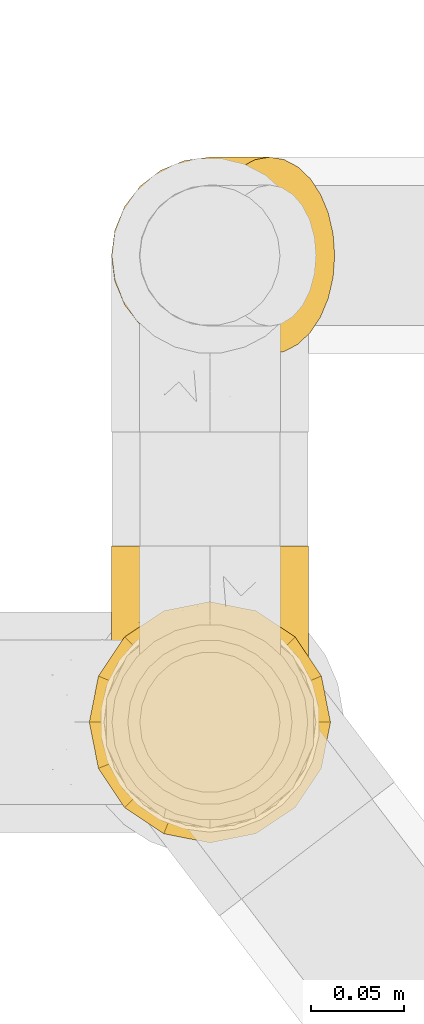
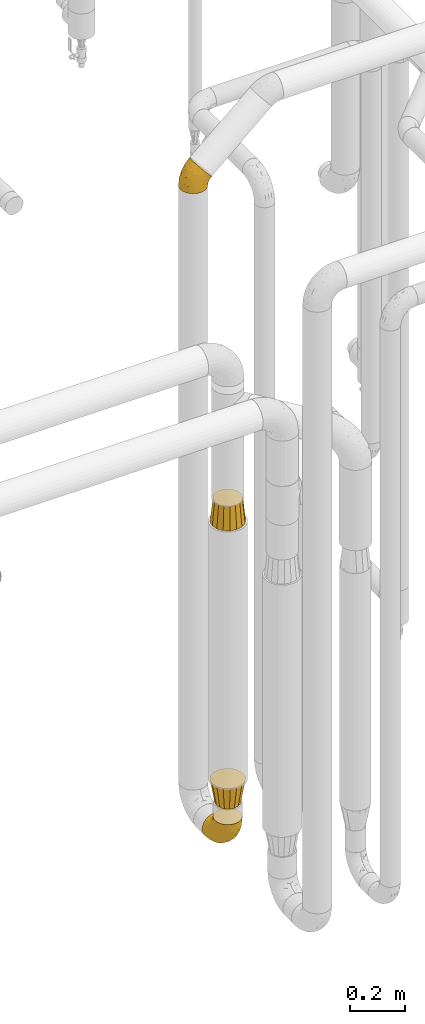
# One storey, part 393 of 827: 4 coverings.
"""IFC2X3 building model written with IfcOpenShell, lengths in millimetres."""

from ifc_helpers import new_model, entity, si_unit, converted_unit, derived_unit, direction, frame, origin, place, context, subcontext, project, spatial, faceted_brep, element, save


model = new_model("IFC2X3")

# Units and contexts
model_context = context("Model", 3, precision=0.01, world=origin(), true_north=direction((6.12303176911189e-17, 1.0)))
body_context = subcontext(model_context, "Body", "Model", "MODEL_VIEW")
ifc_project = project(units=[si_unit("LENGTHUNIT", "METRE", prefix="MILLI"), si_unit("AREAUNIT", "SQUARE_METRE"), si_unit("VOLUMEUNIT", "CUBIC_METRE"), converted_unit("PLANEANGLEUNIT", "DEGREE", entity("IfcRatioMeasure", 0.0174532925199433), si_unit("PLANEANGLEUNIT", "RADIAN"), dimensions=[0, 0, 0, 0, 0, 0, 0]), si_unit("MASSUNIT", "GRAM", prefix="KILO"), derived_unit("MASSDENSITYUNIT", [(si_unit("MASSUNIT", "GRAM", prefix="KILO"), 1), (si_unit("LENGTHUNIT", "METRE"), -3)]), derived_unit("MOMENTOFINERTIAUNIT", [(si_unit("LENGTHUNIT", "METRE"), 4)]), si_unit("TIMEUNIT", "SECOND"), si_unit("FREQUENCYUNIT", "HERTZ"), si_unit("THERMODYNAMICTEMPERATUREUNIT", "DEGREE_CELSIUS"), derived_unit("THERMALTRANSMITTANCEUNIT", [(si_unit("MASSUNIT", "GRAM", prefix="KILO"), 1), (si_unit("THERMODYNAMICTEMPERATUREUNIT", "KELVIN"), -1), (si_unit("TIMEUNIT", "SECOND"), -3)]), derived_unit("VOLUMETRICFLOWRATEUNIT", [(si_unit("LENGTHUNIT", "METRE"), 3), (si_unit("TIMEUNIT", "SECOND"), -1)]), derived_unit("MASSFLOWRATEUNIT", [(si_unit("MASSUNIT", "GRAM", prefix="KILO"), 1), (si_unit("TIMEUNIT", "SECOND"), -1)]), derived_unit("ROTATIONALFREQUENCYUNIT", [(si_unit("TIMEUNIT", "SECOND"), -1)]), si_unit("ELECTRICCURRENTUNIT", "AMPERE"), si_unit("ELECTRICVOLTAGEUNIT", "VOLT"), si_unit("POWERUNIT", "WATT"), si_unit("FORCEUNIT", "NEWTON", prefix="KILO"), si_unit("ILLUMINANCEUNIT", "LUX"), si_unit("LUMINOUSFLUXUNIT", "LUMEN"), si_unit("LUMINOUSINTENSITYUNIT", "CANDELA"), derived_unit("USERDEFINED", [(si_unit("MASSUNIT", "GRAM", prefix="KILO"), -1), (si_unit("LENGTHUNIT", "METRE"), -2), (si_unit("TIMEUNIT", "SECOND"), 3), (si_unit("LUMINOUSFLUXUNIT", "LUMEN"), 1)]), derived_unit("LINEARVELOCITYUNIT", [(si_unit("LENGTHUNIT", "METRE"), 1), (si_unit("TIMEUNIT", "SECOND"), -1)]), si_unit("PRESSUREUNIT", "PASCAL"), derived_unit("USERDEFINED", [(si_unit("LENGTHUNIT", "METRE"), -2), (si_unit("MASSUNIT", "GRAM", prefix="KILO"), 1), (si_unit("TIMEUNIT", "SECOND"), -2)]), derived_unit("LINEARFORCEUNIT", [(si_unit("MASSUNIT", "GRAM", prefix="KILO"), 1), (si_unit("LENGTHUNIT", "METRE"), 1), (si_unit("TIMEUNIT", "SECOND"), -2), (si_unit("LENGTHUNIT", "METRE"), -1)]), derived_unit("PLANARFORCEUNIT", [(si_unit("MASSUNIT", "GRAM", prefix="KILO"), 1), (si_unit("LENGTHUNIT", "METRE"), 1), (si_unit("TIMEUNIT", "SECOND"), -2), (si_unit("LENGTHUNIT", "METRE"), -2)])], contexts=[model_context])

# Site, building, storey
site_placement = place(None, origin())
site = spatial("IfcSite", under=ifc_project, at=site_placement, CompositionType="ELEMENT")
building_placement = place(site_placement, origin())
building = spatial("IfcBuilding", under=site, at=building_placement, CompositionType="ELEMENT")
storey_placement = place(building_placement, frame((0.0, 0.0, 28200.0)))
storey = spatial("IfcBuildingStorey", under=building, at=storey_placement, Name="08", CompositionType="ELEMENT", Elevation=28200.0)

# Coverings
covering_1_placement = place(storey_placement, frame((45439.58, 14231.97, 295.35)))
element("IfcCovering", 1, at=covering_1_placement, inside=storey, Name=":ADSK_", ObjectType=":ADSK_", PredefinedType="INSULATION", context=body_context, shape_type="Brep", body=[
    faceted_brep([(42.85, 2.92, 149.65), (54.65, 1.6, 149.65), (66.46, 2.93, 149.65), (77.67, 6.85, 149.65), (87.73, 13.18, 149.65), (96.13, 21.58, 149.65), (102.45, 31.64, 149.65), (106.37, 42.85, 149.65), (107.7, 54.65, 149.65), (106.36, 66.46, 149.65), (102.44, 77.67, 149.65), (96.11, 87.73, 149.65), (87.71, 96.13, 149.65), (77.65, 102.45, 149.65), (66.44, 106.37, 149.65), (54.65, 107.7, 149.65), (42.84, 106.36, 149.65), (31.62, 102.44, 149.65), (21.56, 96.11, 149.65), (13.16, 87.71, 149.65), (6.84, 77.65, 149.65), (2.92, 66.44, 149.65), (1.6, 54.65, 149.65), (2.93, 42.84, 149.65), (6.85, 31.62, 149.65), (13.18, 21.56, 149.65), (21.58, 13.16, 149.65), (31.64, 6.84, 149.65), (68.38, 149.65, 105.89), (81.17, 149.65, 100.59), (92.16, 149.65, 92.16), (100.59, 149.65, 81.17), (105.89, 149.65, 68.38), (107.7, 149.65, 54.65), (105.89, 149.65, 40.91), (100.59, 149.65, 28.12), (92.16, 149.65, 17.13), (81.17, 149.65, 8.7), (68.38, 149.65, 3.4), (54.65, 149.65, 1.6), (40.91, 149.65, 3.4), (28.12, 149.65, 8.7), (17.13, 149.65, 17.13), (8.7, 149.65, 28.12), (3.4, 149.65, 40.91), (1.6, 149.65, 54.65), (3.4, 149.65, 68.38), (8.7, 149.65, 81.17), (17.13, 149.65, 92.16), (28.12, 149.65, 100.59), (40.91, 149.65, 105.89), (54.65, 149.65, 107.7), (23.76, 123.27, 14.05), (35.87, 114.15, 9.45), (25.52, 92.97, 22.36), (45.07, 124.11, 4.7), (54.65, 111.33, 6.64), (12.57, 42.13, 81.47), (15.93, 56.83, 56.83), (24.82, 40.31, 64.02), (37.92, 61.55, 34.04), (54.65, 75.62, 21.43), (54.65, 44.96, 44.96), (5.82, 91.12, 49.8), (8.38, 109.83, 35.43), (10.19, 88.02, 42.1), (3.86, 119.19, 43.59), (2.5, 99.11, 57.88), (19.48, 27.97, 91.8), (29.7, 21.92, 88.01), (28.0, 12.94, 115.65), (35.28, 88.29, 18.94), (45.15, 95.35, 12.83), (14.54, 113.84, 24.96), (54.65, 6.64, 111.33), (38.55, 8.58, 113.8), (40.99, 33.39, 60.89), (43.24, 17.23, 86.24), (8.56, 61.99, 65.84), (2.51, 47.9, 124.58), (5.69, 37.72, 121.36), (1.6, 93.81, 72.79), (1.6, 107.05, 66.04), (1.6, 120.29, 59.29), (3.22, 73.26, 73.26), (18.7, 18.58, 121.69), (11.86, 29.72, 109.82), (24.78, 64.31, 40.11), (15.99, 82.84, 36.57), (1.6, 72.79, 93.81), (1.6, 83.3, 83.3), (1.6, 56.71, 136.6), (1.6, 59.29, 120.29), (2.5, 57.88, 99.11), (1.6, 66.04, 107.05), (5.82, 49.8, 91.12), (54.65, 21.43, 75.62), (1.6, 134.97, 56.97), (32.3, 108.79, 126.65), (25.01, 110.84, 116.55), (18.18, 101.53, 120.09), (3.03, 111.84, 76.06), (6.69, 119.98, 83.69), (3.21, 123.54, 71.88), (2.73, 134.54, 66.92), (3.93, 80.57, 110.43), (2.55, 69.55, 121.31), (7.7, 134.56, 81.0), (54.65, 128.67, 113.32), (54.65, 136.98, 111.09), (41.58, 133.56, 109.14), (17.93, 131.66, 95.86), (14.97, 117.75, 99.07), (22.2, 118.23, 106.92), (43.45, 110.55, 131.39), (54.65, 111.09, 136.98), (54.65, 113.32, 128.67), (40.37, 120.2, 117.07), (8.47, 105.95, 96.39), (29.46, 127.69, 106.61), (32.17, 139.88, 103.72), (3.39, 92.14, 92.14), (7.76, 93.82, 107.13), (2.57, 82.28, 98.03), (11.54, 130.86, 88.38), (6.21, 78.78, 130.66), (2.9, 67.58, 135.45), (11.19, 90.58, 123.57), (14.27, 90.23, 137.75), (22.4, 99.39, 133.2), (34.87, 105.17, 138.8), (54.65, 120.99, 120.99), (4.01, 104.59, 84.53), (16.42, 108.24, 108.72), (91.36, 131.66, 95.86), (103.07, 78.8, 130.67), (67.71, 133.57, 109.13), (107.7, 72.79, 93.81), (106.72, 82.27, 98.02), (105.35, 80.59, 110.43), (65.83, 110.55, 131.4), (76.97, 108.79, 126.66), (68.91, 120.2, 117.08), (92.85, 108.25, 108.74), (100.82, 106.06, 96.31), (94.28, 117.78, 99.11), (98.08, 90.6, 123.58), (101.51, 93.87, 107.12), (107.7, 93.81, 72.79), (107.7, 107.05, 66.04), (106.25, 111.89, 76.07), (107.7, 134.97, 56.97), (106.56, 134.54, 66.92), (107.7, 59.29, 120.29), (107.7, 66.04, 107.05), (106.74, 69.56, 121.26), (105.31, 104.56, 84.46), (102.6, 119.98, 83.69), (101.59, 134.56, 81.0), (106.08, 123.54, 71.88), (95.01, 90.25, 137.76), (86.87, 99.4, 133.21), (84.27, 110.83, 116.58), (91.11, 101.52, 120.1), (74.4, 105.18, 138.81), (107.7, 56.71, 136.6), (77.12, 139.89, 103.72), (87.06, 118.22, 106.96), (106.38, 67.6, 135.44), (97.75, 130.86, 88.38), (107.7, 83.3, 83.3), (79.83, 127.71, 106.6), (105.91, 92.12, 92.12), (107.7, 120.29, 59.29), (83.77, 92.97, 22.36), (85.53, 123.27, 14.05), (94.75, 113.84, 24.96), (100.91, 109.83, 35.43), (64.22, 124.03, 4.71), (73.42, 114.15, 9.45), (64.15, 98.04, 11.79), (106.79, 99.11, 57.88), (106.79, 47.9, 124.57), (103.61, 37.74, 121.37), (103.47, 49.8, 91.12), (93.36, 56.83, 56.83), (96.75, 42.16, 81.48), (84.48, 40.3, 64.05), (106.79, 57.88, 99.11), (106.07, 73.26, 73.26), (105.43, 119.19, 43.59), (73.44, 86.61, 19.5), (89.82, 27.99, 91.8), (90.61, 18.59, 121.7), (79.61, 21.92, 88.04), (81.34, 11.28, 123.34), (68.3, 33.39, 60.89), (71.37, 61.55, 34.04), (97.44, 29.73, 109.85), (99.1, 88.01, 42.1), (100.74, 62.08, 65.78), (70.76, 8.58, 113.81), (93.3, 82.84, 36.57), (84.5, 64.3, 40.12), (103.47, 91.12, 49.8), (68.73, 18.05, 86.08)], [[[0, 1, 2, 3, 4, 5, 6, 7, 8, 9, 10, 11, 12, 13, 14, 15, 16, 17, 18, 19, 20, 21, 22, 23, 24, 25, 26, 27]], [[28, 29, 30, 31, 32, 33, 34, 35, 36, 37, 38, 39, 40, 41, 42, 43, 44, 45, 46, 47, 48, 49, 50, 51]], [[52, 53, 54]], [[55, 39, 56]], [[57, 58, 59]], [[60, 61, 62]], [[63, 64, 65]], [[66, 63, 67]], [[68, 69, 70]], [[53, 71, 54]], [[41, 40, 53]], [[53, 72, 71]], [[73, 42, 52]], [[42, 41, 52]], [[74, 0, 75]], [[69, 76, 77]], [[43, 73, 64]], [[45, 44, 66]], [[57, 78, 58]], [[23, 79, 80]], [[67, 81, 82, 83]], [[67, 84, 81]], [[24, 23, 80]], [[25, 85, 26]], [[86, 85, 25]], [[42, 73, 43]], [[0, 27, 75]], [[25, 24, 86]], [[70, 26, 85]], [[0, 74, 1]], [[68, 85, 86]], [[66, 64, 63]], [[60, 59, 87]], [[54, 87, 88]], [[76, 60, 62]], [[84, 89, 90, 81]], [[79, 22, 91, 92]], [[77, 74, 75]], [[93, 92, 94, 89]], [[80, 86, 24]], [[40, 55, 53]], [[76, 59, 60]], [[93, 84, 95]], [[76, 62, 96]], [[55, 72, 53]], [[70, 27, 26]], [[75, 70, 69]], [[78, 84, 63]], [[93, 79, 92]], [[95, 86, 80]], [[77, 76, 96]], [[59, 69, 68]], [[57, 68, 86]], [[68, 57, 59]], [[59, 58, 87]], [[76, 69, 59]], [[88, 87, 58]], [[87, 54, 71]], [[86, 95, 57]], [[78, 57, 95]], [[84, 78, 95]], [[78, 63, 65]], [[58, 78, 65]], [[54, 88, 73]], [[84, 93, 89]], [[79, 95, 80]], [[79, 93, 95]], [[22, 79, 23]], [[66, 83, 97, 45]], [[84, 67, 63]], [[83, 66, 67]], [[64, 44, 43]], [[64, 66, 44]], [[65, 73, 88]], [[53, 52, 41]], [[73, 52, 54]], [[73, 65, 64]], [[65, 88, 58]], [[39, 55, 40]], [[72, 55, 56]], [[56, 61, 72]], [[60, 72, 61]], [[72, 60, 71]], [[87, 71, 60]], [[27, 70, 75]], [[68, 70, 85]], [[74, 77, 96]], [[69, 77, 75]], [[98, 99, 100]], [[46, 45, 97]], [[101, 102, 103]], [[103, 104, 83]], [[105, 94, 106]], [[107, 103, 102]], [[108, 109, 51, 110]], [[111, 112, 113]], [[114, 115, 116]], [[47, 104, 107]], [[110, 117, 108]], [[49, 48, 111]], [[102, 118, 112]], [[119, 120, 111]], [[50, 49, 120]], [[121, 122, 118]], [[105, 123, 89]], [[124, 48, 107]], [[20, 19, 125]], [[121, 81, 90]], [[117, 119, 99]], [[21, 20, 126]], [[22, 21, 91]], [[105, 125, 127]], [[110, 51, 50]], [[19, 128, 125]], [[16, 15, 115]], [[129, 98, 100]], [[126, 91, 21]], [[128, 129, 127]], [[122, 123, 105]], [[114, 117, 98]], [[17, 16, 130]], [[18, 128, 19]], [[129, 18, 17]], [[125, 106, 126]], [[115, 114, 16]], [[130, 129, 17]], [[114, 98, 130]], [[117, 116, 131, 108]], [[99, 119, 113]], [[122, 121, 123]], [[92, 126, 106]], [[105, 127, 122]], [[132, 121, 118]], [[114, 130, 16]], [[129, 130, 98]], [[50, 120, 110]], [[129, 128, 18]], [[125, 128, 127]], [[125, 126, 20]], [[91, 126, 92]], [[105, 89, 94]], [[105, 106, 125]], [[94, 92, 106]], [[100, 122, 127]], [[118, 122, 133]], [[112, 118, 133]], [[132, 118, 102]], [[132, 102, 101]], [[81, 121, 132]], [[82, 103, 83]], [[132, 101, 81]], [[104, 47, 46]], [[124, 107, 102]], [[48, 47, 107]], [[113, 112, 133]], [[112, 111, 124]], [[99, 113, 133]], [[111, 113, 119]], [[99, 133, 100]], [[117, 99, 98]], [[122, 100, 133]], [[127, 129, 100]], [[103, 82, 101]], [[81, 101, 82]], [[112, 124, 102]], [[48, 124, 111]], [[104, 103, 107]], [[46, 97, 104]], [[111, 120, 49]], [[83, 104, 97]], [[110, 120, 119]], [[117, 110, 119]], [[116, 117, 114]], [[89, 123, 90]], [[90, 123, 121]], [[30, 29, 134]], [[11, 10, 135]], [[51, 109, 108, 136]], [[137, 138, 139]], [[140, 141, 142]], [[143, 144, 145]], [[146, 139, 147]], [[148, 149, 150]], [[151, 32, 152]], [[153, 154, 155]], [[156, 150, 157]], [[158, 157, 159]], [[108, 142, 136]], [[31, 158, 152]], [[160, 161, 12]], [[162, 163, 143]], [[140, 142, 116]], [[142, 141, 162]], [[14, 164, 140]], [[14, 140, 115]], [[9, 8, 165]], [[160, 12, 11]], [[141, 164, 161]], [[13, 12, 161]], [[14, 115, 15]], [[28, 166, 29]], [[135, 139, 146]], [[141, 163, 162]], [[135, 146, 160]], [[143, 167, 162]], [[29, 166, 134]], [[116, 142, 108, 131]], [[165, 153, 168]], [[10, 9, 168]], [[168, 135, 10]], [[138, 147, 139]], [[158, 169, 157]], [[14, 13, 164]], [[116, 115, 140]], [[145, 167, 143]], [[135, 160, 11]], [[168, 153, 155]], [[138, 137, 170]], [[157, 144, 156]], [[147, 144, 143]], [[161, 164, 13]], [[140, 164, 141]], [[142, 171, 136]], [[136, 171, 166]], [[161, 160, 146]], [[165, 168, 9]], [[155, 139, 135]], [[139, 154, 137]], [[168, 155, 135]], [[139, 155, 154]], [[144, 147, 172]], [[163, 147, 143]], [[156, 144, 172]], [[157, 169, 145]], [[172, 148, 156]], [[173, 159, 149]], [[159, 157, 150]], [[152, 159, 173]], [[159, 152, 158]], [[31, 30, 158]], [[169, 30, 134]], [[157, 145, 144]], [[167, 134, 171]], [[134, 167, 145]], [[171, 142, 162]], [[162, 167, 171]], [[163, 141, 161]], [[161, 146, 163]], [[147, 163, 146]], [[148, 150, 156]], [[149, 159, 150]], [[30, 169, 158]], [[145, 169, 134]], [[151, 33, 32]], [[31, 152, 32]], [[152, 173, 151]], [[28, 51, 136]], [[134, 166, 171]], [[28, 136, 166]], [[138, 170, 172]], [[147, 138, 172]], [[148, 172, 170]], [[174, 175, 176]], [[35, 34, 177]], [[178, 179, 180]], [[181, 173, 149, 148]], [[182, 183, 184]], [[185, 186, 187]], [[188, 189, 137]], [[190, 33, 151, 173]], [[191, 179, 174]], [[34, 190, 177]], [[39, 38, 178]], [[192, 193, 194]], [[4, 3, 195]], [[175, 179, 37]], [[38, 37, 179]], [[35, 176, 36]], [[196, 62, 197]], [[181, 190, 173]], [[37, 36, 175]], [[183, 6, 198]], [[189, 148, 170, 137]], [[185, 199, 200]], [[3, 2, 201]], [[202, 185, 203]], [[8, 7, 182]], [[200, 184, 186]], [[183, 7, 6]], [[181, 189, 204]], [[200, 189, 184]], [[5, 198, 6]], [[187, 203, 185]], [[195, 3, 201]], [[205, 196, 194]], [[62, 61, 197]], [[186, 198, 192]], [[180, 179, 191]], [[2, 1, 74]], [[198, 193, 192]], [[193, 5, 4]], [[194, 193, 195]], [[2, 74, 201]], [[5, 193, 198]], [[205, 74, 96]], [[188, 137, 154, 153]], [[62, 196, 96]], [[56, 178, 180]], [[198, 184, 183]], [[184, 188, 182]], [[203, 197, 191]], [[205, 194, 201]], [[187, 192, 194]], [[192, 187, 186]], [[194, 196, 187]], [[197, 187, 196]], [[197, 203, 187]], [[202, 174, 176]], [[200, 186, 185]], [[184, 198, 186]], [[199, 185, 202]], [[189, 200, 204]], [[174, 202, 203]], [[176, 177, 199]], [[189, 181, 148]], [[190, 181, 204]], [[190, 204, 177]], [[190, 34, 33]], [[188, 153, 182]], [[189, 188, 184]], [[182, 153, 165, 8]], [[183, 182, 7]], [[199, 177, 204]], [[35, 177, 176]], [[176, 175, 36]], [[179, 175, 174]], [[200, 199, 204]], [[176, 199, 202]], [[203, 191, 174]], [[180, 197, 61]], [[197, 180, 191]], [[61, 56, 180]], [[39, 178, 56]], [[38, 179, 178]], [[194, 195, 201]], [[4, 195, 193]], [[74, 205, 201]], [[96, 196, 205]]]),
])
covering_2_placement = place(storey_placement, frame((45439.58, 14483.43, 3080.72)))
element("IfcCovering", 2, at=covering_2_placement, inside=storey, Name=":ADSK_", ObjectType=":ADSK_", PredefinedType="INSULATION", context=body_context, shape_type="Brep", body=[
    faceted_brep([(121.02, 66.46, 34.06), (118.43, 77.67, 37.01), (114.25, 87.73, 41.75), (108.69, 96.13, 48.05), (102.04, 102.45, 55.6), (94.62, 106.37, 64.01), (86.82, 107.7, 72.86), (79.01, 106.36, 81.72), (71.6, 102.44, 90.13), (64.95, 96.11, 97.68), (59.39, 87.71, 103.98), (55.21, 77.65, 108.72), (52.62, 66.44, 111.66), (51.74, 54.65, 112.65), (52.62, 42.84, 111.65), (55.22, 31.62, 108.71), (59.4, 21.56, 103.97), (64.96, 13.16, 97.66), (71.61, 6.84, 90.12), (79.02, 2.92, 81.71), (86.82, 1.6, 72.86), (94.63, 2.93, 64.0), (102.05, 6.85, 55.59), (108.7, 13.18, 48.04), (114.26, 21.58, 41.74), (118.43, 31.64, 37.0), (121.03, 42.85, 34.06), (121.9, 54.65, 33.06), (105.89, 40.91, 1.6), (100.59, 28.12, 1.6), (92.16, 17.13, 1.6), (81.17, 8.7, 1.6), (68.38, 3.4, 1.6), (54.65, 1.6, 1.6), (40.91, 3.4, 1.6), (28.12, 8.7, 1.6), (17.13, 17.13, 1.6), (8.7, 28.12, 1.6), (3.4, 40.91, 1.6), (1.6, 54.65, 1.6), (3.4, 68.38, 1.6), (8.7, 81.17, 1.6), (17.13, 92.16, 1.6), (28.12, 100.59, 1.6), (40.91, 105.89, 1.6), (54.65, 107.7, 1.6), (68.38, 105.89, 1.6), (81.17, 100.59, 1.6), (92.16, 92.16, 1.6), (100.59, 81.17, 1.6), (105.89, 68.38, 1.6), (107.7, 54.65, 1.6), (14.95, 86.09, 30.33), (28.17, 95.39, 44.9), (7.47, 54.65, 42.9), (7.95, 64.78, 40.99), (8.81, 74.21, 33.06), (21.54, 81.22, 60.31), (59.35, 104.24, 70.9), (39.02, 91.11, 76.37), (24.64, 54.65, 80.93), (30.5, 71.42, 84.81), (45.66, 106.35, 26.17), (35.3, 103.12, 24.16), (38.7, 82.11, 87.62), (46.58, 104.52, 48.13), (26.04, 89.14, 56.63), (16.18, 70.73, 59.67), (49.63, 98.81, 75.56), (60.82, 106.72, 57.81), (78.24, 107.7, 62.81), (69.44, 107.7, 52.5), (58.42, 107.7, 28.1), (63.93, 107.7, 40.3), (56.51, 107.7, 14.68), (85.72, 98.9, 16.95), (96.51, 88.57, 12.35), (72.2, 105.3, 18.32), (84.72, 102.89, 34.81), (100.25, 94.37, 35.38), (94.16, 94.16, 23.37), (94.95, 101.22, 44.63), (102.3, 85.95, 23.51), (110.55, 73.8, 24.92), (104.46, 76.39, 13.02), (108.3, 65.07, 13.37), (85.21, 106.02, 51.93), (75.66, 106.6, 41.98), (69.76, 106.77, 30.97), (109.27, 84.29, 32.77), (111.41, 54.65, 18.86), (112.76, 63.94, 23.24), (114.39, 46.22, 25.56), (109.05, 44.56, 15.51), (106.75, 24.47, 29.85), (91.99, 7.61, 42.11), (102.41, 15.38, 37.5), (86.21, 3.37, 52.6), (108.1, 34.96, 20.72), (100.27, 24.19, 16.44), (58.42, 1.6, 28.1), (56.51, 1.6, 14.68), (72.58, 4.37, 14.11), (93.74, 13.45, 27.39), (85.69, 10.63, 15.19), (104.0, 33.25, 10.26), (93.47, 17.33, 12.88), (79.26, 3.57, 41.03), (78.24, 1.6, 62.81), (113.95, 36.16, 29.45), (76.8, 4.6, 27.76), (69.44, 1.6, 52.5), (63.93, 1.6, 40.3), (35.3, 6.17, 24.16), (28.17, 13.9, 44.9), (14.95, 23.2, 30.32), (45.66, 2.94, 26.17), (39.04, 18.16, 76.37), (49.64, 10.47, 75.55), (59.36, 5.04, 70.89), (46.58, 4.77, 48.13), (7.96, 44.5, 41.05), (60.81, 2.57, 57.77), (8.81, 35.08, 33.08), (21.55, 28.06, 60.31), (16.2, 38.53, 59.68), (30.5, 37.86, 84.8), (26.07, 20.14, 56.66), (38.7, 27.17, 87.61)], [[[0, 1, 2, 3, 4, 5, 6, 7, 8, 9, 10, 11, 12, 13, 14, 15, 16, 17, 18, 19, 20, 21, 22, 23, 24, 25, 26, 27]], [[28, 29, 30, 31, 32, 33, 34, 35, 36, 37, 38, 39, 40, 41, 42, 43, 44, 45, 46, 47, 48, 49, 50, 51]], [[52, 53, 42]], [[39, 54, 55]], [[41, 52, 42]], [[56, 57, 52]], [[8, 7, 58]], [[59, 10, 9]], [[60, 12, 61]], [[43, 42, 53]], [[62, 45, 44]], [[44, 63, 62]], [[43, 63, 44]], [[64, 57, 61]], [[65, 63, 53]], [[53, 66, 59]], [[61, 67, 60]], [[57, 56, 67]], [[9, 68, 59]], [[64, 61, 11]], [[64, 10, 59]], [[12, 60, 13]], [[68, 58, 65]], [[7, 6, 69]], [[41, 40, 56]], [[52, 57, 66]], [[68, 9, 8]], [[69, 6, 70, 71]], [[62, 69, 72]], [[58, 69, 65]], [[53, 68, 65]], [[58, 68, 8]], [[59, 68, 53]], [[57, 67, 61]], [[56, 52, 41]], [[61, 12, 11]], [[7, 69, 58]], [[55, 40, 39]], [[69, 71, 73, 72]], [[53, 63, 43]], [[62, 63, 65]], [[69, 62, 65]], [[62, 72, 74, 45]], [[10, 64, 11]], [[57, 64, 59]], [[56, 55, 67]], [[67, 55, 60]], [[40, 55, 56]], [[60, 55, 54]], [[52, 66, 53]], [[57, 59, 66]], [[75, 76, 48]], [[72, 77, 74]], [[75, 47, 77]], [[74, 77, 46]], [[78, 79, 80]], [[81, 79, 78]], [[2, 79, 3]], [[82, 83, 84]], [[85, 51, 50]], [[49, 84, 50]], [[47, 75, 48]], [[77, 47, 46]], [[76, 75, 80]], [[84, 85, 50]], [[86, 78, 87]], [[79, 81, 3]], [[4, 3, 81]], [[86, 5, 4]], [[81, 86, 4]], [[86, 70, 5]], [[73, 87, 88]], [[77, 78, 75]], [[89, 79, 2]], [[90, 91, 27]], [[90, 85, 91]], [[0, 83, 1]], [[2, 1, 89]], [[48, 76, 49]], [[82, 89, 83]], [[80, 82, 76]], [[70, 86, 71]], [[84, 49, 76]], [[70, 6, 5]], [[86, 81, 78]], [[83, 91, 85]], [[83, 85, 84]], [[51, 85, 90]], [[83, 89, 1]], [[79, 89, 82]], [[88, 72, 73]], [[86, 87, 71]], [[84, 76, 82]], [[78, 80, 75]], [[79, 82, 80]], [[46, 45, 74]], [[83, 0, 91]], [[27, 91, 0]], [[88, 78, 77]], [[71, 87, 73]], [[78, 88, 87]], [[72, 88, 77]], [[90, 92, 93]], [[25, 24, 94]], [[90, 93, 51]], [[95, 96, 23]], [[97, 22, 21]], [[98, 94, 99]], [[100, 101, 102]], [[94, 96, 103]], [[104, 31, 30]], [[99, 29, 105]], [[29, 99, 106]], [[102, 32, 31]], [[95, 97, 107]], [[97, 21, 108]], [[109, 92, 26]], [[102, 104, 110]], [[109, 26, 25]], [[23, 22, 95]], [[96, 24, 23]], [[106, 104, 30]], [[29, 28, 105]], [[94, 98, 109]], [[95, 103, 96]], [[95, 110, 103]], [[107, 111, 112]], [[96, 94, 24]], [[111, 97, 108]], [[97, 95, 22]], [[95, 107, 110]], [[102, 101, 32]], [[103, 104, 106]], [[92, 27, 26]], [[103, 110, 104]], [[94, 103, 99]], [[21, 20, 108]], [[97, 111, 107]], [[112, 110, 107]], [[104, 102, 31]], [[100, 110, 112]], [[100, 102, 110]], [[94, 109, 25]], [[33, 32, 101]], [[98, 93, 92]], [[98, 92, 109]], [[27, 92, 90]], [[105, 93, 98]], [[51, 93, 28]], [[93, 105, 28]], [[99, 105, 98]], [[29, 106, 30]], [[103, 106, 99]], [[35, 34, 113]], [[114, 115, 36]], [[116, 33, 101, 100]], [[117, 118, 17]], [[119, 118, 120]], [[36, 35, 114]], [[38, 121, 39]], [[122, 120, 116]], [[123, 38, 37]], [[118, 119, 18]], [[114, 35, 113]], [[37, 115, 123]], [[122, 119, 120]], [[19, 18, 119]], [[122, 100, 112, 111]], [[123, 115, 124]], [[20, 19, 122]], [[36, 115, 37]], [[117, 17, 16]], [[125, 124, 126]], [[127, 114, 117]], [[113, 116, 120]], [[38, 123, 121]], [[120, 118, 114]], [[123, 124, 125]], [[15, 126, 128]], [[14, 13, 60]], [[14, 60, 126]], [[114, 127, 115]], [[124, 117, 128]], [[60, 54, 121]], [[14, 126, 15]], [[16, 15, 128]], [[122, 19, 119]], [[114, 118, 117]], [[18, 17, 118]], [[122, 111, 108, 20]], [[116, 113, 34]], [[114, 113, 120]], [[33, 116, 34]], [[122, 116, 100]], [[124, 128, 126]], [[16, 128, 117]], [[60, 125, 126]], [[121, 123, 125]], [[60, 121, 125]], [[121, 54, 39]], [[117, 124, 127]], [[115, 127, 124]]]),
])
covering_3_placement = place(storey_placement, frame((45427.63, 14220.02, 510.0)))
element("IfcCovering", 3, at=covering_3_placement, inside=storey, Name=":ADSK_", ObjectType=":ADSK_", PredefinedType="INSULATION", context=body_context, shape_type="Brep", body=[
    faceted_brep([(1.6, 66.6, 102.0), (4.38, 52.61, 102.0), (6.54, 41.72, 102.0), (13.59, 31.18, 102.0), (20.63, 20.63, 102.0), (31.18, 13.59, 102.0), (41.72, 6.54, 102.0), (52.61, 4.38, 102.0), (66.6, 1.6, 102.0), (80.58, 4.38, 102.0), (91.47, 6.54, 102.0), (102.01, 13.59, 102.0), (112.56, 20.63, 102.0), (119.6, 31.18, 102.0), (126.65, 41.72, 102.0), (128.81, 52.61, 102.0), (131.6, 66.6, 102.0), (128.81, 80.58, 102.0), (126.65, 91.47, 102.0), (119.6, 102.01, 102.0), (112.56, 112.56, 102.0), (102.01, 119.6, 102.0), (91.47, 126.65, 102.0), (80.58, 128.81, 102.0), (66.6, 131.6, 102.0), (52.61, 128.81, 102.0), (41.72, 126.65, 102.0), (31.18, 119.6, 102.0), (20.63, 112.56, 102.0), (13.59, 102.01, 102.0), (6.54, 91.47, 102.0), (4.38, 80.58, 102.0), (84.77, 110.48, 0.0), (92.48, 105.33, 0.0), (100.18, 100.18, 0.0), (105.33, 92.48, 0.0), (110.48, 84.77, 0.0), (112.29, 75.68, 0.0), (114.1, 66.6, 0.0), (112.29, 57.51, 0.0), (110.48, 48.42, 0.0), (105.33, 40.71, 0.0), (100.18, 33.01, 0.0), (92.48, 27.86, 0.0), (84.77, 22.71, 0.0), (75.68, 20.9, 0.0), (66.6, 19.1, 0.0), (57.51, 20.9, 0.0), (48.42, 22.71, 0.0), (40.71, 27.86, 0.0), (33.01, 33.01, 0.0), (27.86, 40.71, 0.0), (22.71, 48.42, 0.0), (20.9, 57.51, 0.0), (19.1, 66.6, 0.0), (20.9, 75.68, 0.0), (22.71, 84.77, 0.0), (27.86, 92.48, 0.0), (33.01, 100.18, 0.0), (40.71, 105.33, 0.0), (48.42, 110.48, 0.0), (57.51, 112.29, 0.0), (66.6, 114.1, 0.0), (75.68, 112.29, 0.0)], [[[0, 1, 2, 3, 4, 5, 6, 7, 8, 9, 10, 11, 12, 13, 14, 15, 16, 17, 18, 19, 20, 21, 22, 23, 24, 25, 26, 27, 28, 29, 30, 31]], [[32, 33, 34, 35, 36, 37, 38, 39, 40, 41, 42, 43, 44, 45, 46, 47, 48, 49, 50, 51, 52, 53, 54, 55, 56, 57, 58, 59, 60, 61, 62, 63]], [[52, 2, 1, 0, 54, 53]], [[50, 4, 3, 2, 52, 51]], [[8, 7, 6, 48, 47, 46]], [[4, 50, 49, 48, 6, 5]], [[44, 10, 9, 8, 46, 45]], [[42, 12, 11, 10, 44, 43]], [[16, 15, 14, 40, 39, 38]], [[12, 42, 41, 40, 14, 13]], [[36, 18, 17, 16, 38, 37]], [[34, 20, 19, 18, 36, 35]], [[24, 23, 22, 32, 63, 62]], [[20, 34, 33, 32, 22, 21]], [[60, 26, 25, 24, 62, 61]], [[58, 28, 27, 26, 60, 59]], [[0, 31, 30, 56, 55, 54]], [[28, 58, 57, 56, 30, 29]]]),
])
covering_4_placement = place(storey_placement, frame((45427.63, 14220.02, 1752.0)))
element("IfcCovering", 4, at=covering_4_placement, inside=storey, Name=":ADSK_", ObjectType=":ADSK_", PredefinedType="INSULATION", context=body_context, shape_type="Brep", body=[
    faceted_brep([(117.41, 45.55, 102.0), (119.5, 56.07, 102.0), (121.6, 66.6, 102.0), (119.5, 77.12, 102.0), (117.41, 87.64, 102.0), (111.45, 96.56, 102.0), (105.49, 105.49, 102.0), (96.56, 111.45, 102.0), (87.64, 117.41, 102.0), (77.12, 119.5, 102.0), (66.6, 121.6, 102.0), (56.07, 119.5, 102.0), (45.55, 117.41, 102.0), (36.63, 111.45, 102.0), (27.7, 105.49, 102.0), (21.74, 96.56, 102.0), (15.78, 87.64, 102.0), (13.69, 77.12, 102.0), (11.6, 66.6, 102.0), (13.69, 56.07, 102.0), (15.78, 45.55, 102.0), (21.74, 36.63, 102.0), (27.7, 27.7, 102.0), (36.63, 21.74, 102.0), (45.55, 15.78, 102.0), (56.07, 13.69, 102.0), (66.6, 11.6, 102.0), (77.12, 13.69, 102.0), (87.64, 15.78, 102.0), (96.56, 21.74, 102.0), (105.49, 27.7, 102.0), (111.45, 36.63, 102.0), (112.56, 20.63, 0.0), (102.01, 13.59, 0.0), (91.47, 6.54, 0.0), (81.18, 4.5, 0.0), (66.6, 1.6, 0.0), (52.01, 4.5, 0.0), (41.72, 6.54, 0.0), (31.18, 13.59, 0.0), (20.63, 20.63, 0.0), (13.59, 31.18, 0.0), (6.54, 41.72, 0.0), (4.5, 52.01, 0.0), (1.6, 66.6, 0.0), (4.5, 81.18, 0.0), (6.54, 91.47, 0.0), (13.59, 102.01, 0.0), (20.63, 112.56, 0.0), (31.18, 119.6, 0.0), (41.72, 126.65, 0.0), (52.01, 128.69, 0.0), (66.6, 131.6, 0.0), (81.18, 128.69, 0.0), (91.47, 126.65, 0.0), (102.01, 119.6, 0.0), (112.56, 112.56, 0.0), (119.6, 102.01, 0.0), (126.65, 91.47, 0.0), (128.69, 81.18, 0.0), (131.6, 66.6, 0.0), (128.69, 52.01, 0.0), (126.65, 41.72, 0.0), (119.6, 31.18, 0.0)], [[[0, 1, 2, 3, 4, 5, 6, 7, 8, 9, 10, 11, 12, 13, 14, 15, 16, 17, 18, 19, 20, 21, 22, 23, 24, 25, 26, 27, 28, 29, 30, 31]], [[32, 33, 34, 35, 36, 37, 38, 39, 40, 41, 42, 43, 44, 45, 46, 47, 48, 49, 50, 51, 52, 53, 54, 55, 56, 57, 58, 59, 60, 61, 62, 63]], [[16, 46, 45, 44, 18, 17]], [[47, 46, 16, 15, 14, 48]], [[11, 10, 52, 51, 50, 12]], [[49, 48, 14, 13, 12, 50]], [[24, 38, 37, 36, 26, 25]], [[39, 38, 24, 23, 22, 40]], [[19, 18, 44, 43, 42, 20]], [[41, 40, 22, 21, 20, 42]], [[0, 62, 61, 60, 2, 1]], [[63, 62, 0, 31, 30, 32]], [[27, 26, 36, 35, 34, 28]], [[33, 32, 30, 29, 28, 34]], [[8, 54, 53, 52, 10, 9]], [[55, 54, 8, 7, 6, 56]], [[3, 2, 60, 59, 58, 4]], [[57, 56, 6, 5, 4, 58]]]),
])

save(model, "model.ifc")
